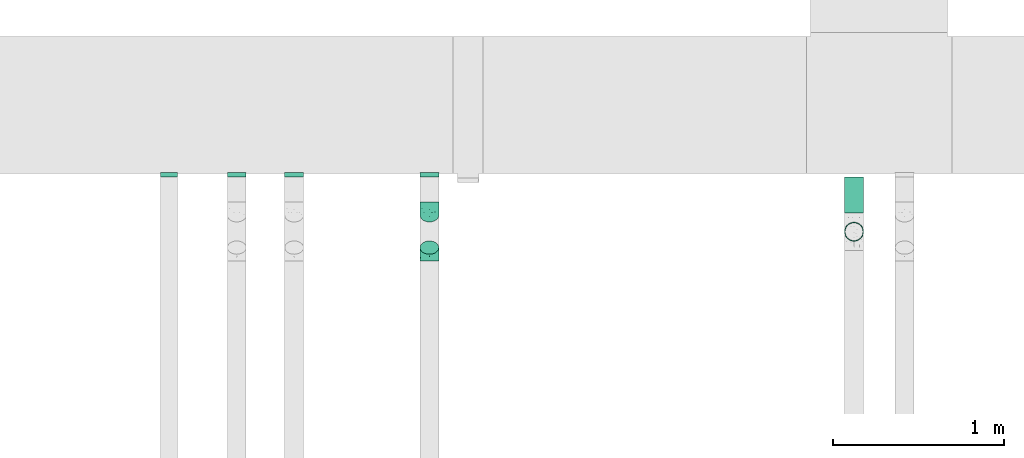
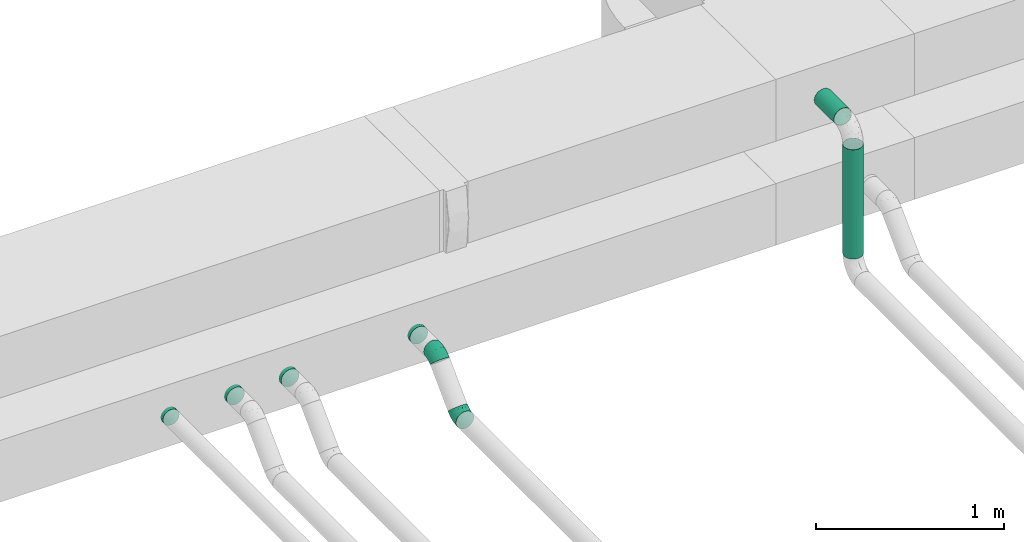
# One storey, part 45 of 91: 6 flow fittings, 2 flow segments.
"""IFC2X3 building model written with IfcOpenShell, lengths in millimetres."""

from ifc_helpers import new_model, entity, si_unit, converted_unit, derived_unit, direction, frame, origin_with_axes, origin_2d_with_axis, place, context, subcontext, project, spatial, hollow_circle, extrude, open_shell, surface_model, source, transform, mapped, material, layer, layer_set, layer_usage, type_object, element, save


model = new_model("IFC2X3")

# Units and contexts
model_context = context("Model", 3, precision=1e-05, world=origin_with_axes(), true_north=direction((0.0, 1.0)))
body_context = subcontext(model_context, "Body", "Model", "MODEL_VIEW")
ifc_project = project(units=[si_unit("AREAUNIT", "SQUARE_METRE"), si_unit("VOLUMEUNIT", "CUBIC_METRE", prefix="DECI"), si_unit("TIMEUNIT", "SECOND"), si_unit("THERMODYNAMICTEMPERATUREUNIT", "DEGREE_CELSIUS"), si_unit("PRESSUREUNIT", "PASCAL"), si_unit("MASSUNIT", "GRAM", prefix="KILO"), si_unit("LENGTHUNIT", "METRE", prefix="MILLI"), si_unit("POWERUNIT", "WATT"), si_unit("ELECTRICCURRENTUNIT", "AMPERE"), si_unit("ELECTRICVOLTAGEUNIT", "VOLT"), derived_unit("VOLUMETRICFLOWRATEUNIT", [(si_unit("VOLUMEUNIT", "CUBIC_METRE", prefix="DECI"), 1), (si_unit("TIMEUNIT", "SECOND"), -1)]), derived_unit("LINEARVELOCITYUNIT", [(si_unit("LENGTHUNIT", "METRE"), 1), (si_unit("TIMEUNIT", "SECOND"), -1)]), derived_unit("MASSDENSITYUNIT", [(si_unit("MASSUNIT", "GRAM", prefix="KILO"), 1), (si_unit("VOLUMEUNIT", "CUBIC_METRE"), -1)]), converted_unit("PLANEANGLEUNIT", "DEGREE", entity("IfcRatioMeasure", 0.01745), si_unit("PLANEANGLEUNIT", "RADIAN"), dimensions=[0, 0, 0, 0, 0, 0, 0])], contexts=[model_context])

# Site, building, storey
site_placement = place(None, origin_with_axes())
site = spatial("IfcSite", under=ifc_project, at=site_placement, CompositionType="ELEMENT")
building_placement = place(site_placement, origin_with_axes())
building = spatial("IfcBuilding", under=site, at=building_placement, Name="mc-building", CompositionType="ELEMENT")
storey_placement = place(building_placement, frame((0.0, 0.0, 8700.0), z_axis=(0.0, 0.0, 1.0), x_axis=(1.0, 0.0, 0.0)))
storey = spatial("IfcBuildingStorey", under=building, at=storey_placement, CompositionType="ELEMENT", Elevation=8700.0)

# Flow segments
ifc_material = material(Name="FZ1")
ifc_layer = layer(ifc_material, 0.0)
ifc_layer_set = layer_set([ifc_layer], Name="FZ1")
ifc_layer_usage = layer_usage(ifc_layer_set, "AXIS1", "POSITIVE", 0.0)
duct_segment_type = type_object("IfcDuctSegmentType", PredefinedType="RIGIDSEGMENT")
shared_shape_1 = source(origin_with_axes(), body_context, "Body", "SweptSolid", [
    extrude(hollow_circle(Radius=55.0, WallThickness=2.0, at=origin_2d_with_axis()), frame((0.0, 0.0, 0.0), z_axis=(1.0, 0.0, 0.0), x_axis=(0.0, 1.0, 0.0)), (0.0, 0.0, 1.0), 709.0),
])
flow_segment_1_placement = place(storey_placement, frame((22753.47863, 2612.35324, 1234.0), z_axis=(0.0, 1.0, 0.0), x_axis=(0.0, 0.0, -1.0)))
element("IfcFlowSegment", 1, at=flow_segment_1_placement, inside=storey, type_object=duct_segment_type, material=ifc_layer_usage, context=body_context, shape_type="MappedRepresentation", body=[
    mapped(shared_shape_1, transform((0.0, 0.0, 0.0), scale=1.0)),
])
shared_shape_2 = source(origin_with_axes(), body_context, "Body", "SweptSolid", [
    extrude(hollow_circle(Radius=55.0, WallThickness=2.0, at=origin_2d_with_axis()), frame((0.0, 0.0, 0.0), z_axis=(1.0, 0.0, 0.0), x_axis=(0.0, 1.0, 0.0)), (0.0, 0.0, 1.0), 208.9),
])
flow_segment_2_placement = place(storey_placement, frame((22753.47863, 2931.20513, 1344.0), z_axis=(0.0, 0.0, 1.0), x_axis=(0.0, -1.0, 0.0)))
element("IfcFlowSegment", 2, at=flow_segment_2_placement, inside=storey, type_object=duct_segment_type, material=ifc_layer_usage, context=body_context, shape_type="MappedRepresentation", body=[
    mapped(shared_shape_2, transform((0.0, 0.0, 0.0), scale=1.0)),
])

# Flow fittings
duct_fitting_type_1 = type_object("IfcDuctFittingType", Name="BU", PredefinedType="BEND")
shared_shape_3 = source(origin_with_axes(), body_context, "Body", "SurfaceModel", [
    surface_model("IfcShellBasedSurfaceModel", [(-45.56349, 0.0, -55.0), (-45.56349, -14.23505, -53.12592), (-45.56349, 14.23505, -53.12592), (-45.56349, 53.12592, 14.23505), (-45.56349, 27.5, -47.63139), (-45.56349, 38.89087, -38.89087), (-45.56349, 47.63139, -27.5), (-45.56349, -55.0, 0.0), (-45.56349, -53.12592, 14.23505), (-45.56349, -38.89087, -38.89087), (-45.56349, -27.5, -47.63139), (-45.56349, -53.12592, -14.23505), (-45.56349, -47.63139, -27.5), (-45.56349, 53.12592, -14.23505), (-45.56349, 47.63139, 27.5), (-45.56349, 38.89087, 38.89087), (-45.56349, -14.23505, 53.12592), (-45.56349, 27.5, 47.63139), (-45.56349, 14.23505, 53.12592), (-45.56349, -47.63139, 27.5), (-45.56349, -38.89087, 38.89087), (-45.56349, -27.5, 47.63139), (-45.56349, 0.0, 55.0), (-45.56349, 55.0, 0.0), (22.15256, 42.28395, -53.12592), (-6.67262, 71.10913, 0.0), (32.21826, 32.21826, -55.0), (12.77282, 51.66369, -47.63139), (-1.46223, 65.89874, -27.5), (4.71825, 59.71825, -38.89087), (59.71825, 4.71825, -38.89087), (69.78395, -5.34744, 14.23505), (51.66369, 12.77282, -47.63139), (42.28395, 22.15256, -53.12592), (65.89874, -1.46223, -27.5), (69.78395, -5.34744, -14.23505), (71.10913, -6.67262, 0.0), (-5.34744, 69.78395, -14.23505), (-5.34744, 69.78395, 14.23505), (-1.46223, 65.89874, 27.5), (4.71825, 59.71825, 38.89087), (32.21826, 32.21826, 55.0), (12.77282, 51.66369, 47.63139), (22.15256, 42.28395, 53.12592), (59.71825, 4.71825, 38.89087), (65.89874, -1.46223, 27.5), (42.28395, 22.15256, 53.12592), (51.66369, 12.77282, 47.63139), (-20.16649, 48.68621, 33.48188), (-26.97111, 35.77503, 43.63444), (-7.30443, 43.73336, 43.63444), (-17.0934, 3.74816, 55.0), (-18.00408, 15.44793, 53.78143), (-30.11707, 22.39897, 50.81337), (-7.49776, 55.63651, 33.48188), (-15.97018, 58.74288, 21.04759), (-31.18231, 52.58712, 21.04759), (-18.35174, 61.03934, 10.51509), (-28.67677, 56.60048, 10.47121), (-34.03924, 44.64267, 33.48188), (-11.52288, 27.81868, 50.81338), (1.19951, 23.16465, 53.81115), (-33.77926, 57.34403, 0.0), (5.4586, 37.12132, 50.81809), (-24.5159, 59.18663, 0.0), (-16.66281, 64.4339, 0.0), (9.43651, 14.73721, 55.0), (-6.22531, 44.36822, -43.63444), (5.4586, 37.12132, -50.81809), (-34.03924, 44.64267, -33.48188), (9.43651, 14.73721, -55.0), (-17.0934, 3.74816, -55.0), (1.19951, 23.16465, -53.81115), (-11.52288, 27.81868, -50.81338), (-30.11707, 22.39897, -50.81337), (-25.75914, 36.08917, -43.63444), (-30.24487, 52.83011, -21.04759), (-20.16649, 48.68621, -33.48188), (-7.49776, 55.63651, -33.48188), (-18.00408, 15.44793, -53.78143), (-28.68366, 56.62226, -10.35271), (-14.15883, 63.53074, -10.87592), (-15.13548, 59.23394, -21.04759), (3.19797, -7.72059, -52.16847), (3.1272, -18.04126, -47.9241), (13.63233, -32.91136, -32.06475), (45.23618, -22.99734, -20.4997), (16.67434, -40.25541, -15.9539), (-17.3935, -51.68264, -9.80849), (-2.85835, -49.37776, 0.0), (48.84421, -24.24609, -9.80849), (-16.38424, -42.76862, -30.85433), (-6.97383, -29.41689, -42.70541), (41.82739, -18.65658, -30.85433), (-15.72523, -48.24839, -20.4997), (29.28945, -13.63928, -42.80781), (26.81493, -3.56603, -49.15704), (36.93651, -32.89419, 0.0), (-15.72523, -48.24839, 20.4997), (-17.3935, -51.68264, 9.80849), (-16.38424, -42.76862, 30.85433), (16.67434, -40.25541, 15.9539), (3.19797, -7.72059, 52.16847), (10.54583, -14.96836, 47.9241), (13.63233, -32.91136, 32.06475), (45.23618, -22.99734, 20.4997), (41.82739, -18.65658, 30.85433), (-11.06635, -30.3552, 42.80781), (25.73213, -15.86964, 42.70541), (-16.43945, -21.48258, 49.15704), (48.84421, -24.24609, 9.80849)], [open_shell([[[0, 1, 2]], [[2, 3, 4]], [[5, 3, 6]], [[4, 3, 5]], [[2, 7, 8]], [[9, 7, 10]], [[1, 10, 7]], [[11, 7, 12]], [[9, 12, 7]], [[7, 2, 1]], [[13, 6, 3]], [[14, 3, 2]], [[15, 14, 2]], [[16, 17, 2]], [[2, 17, 15]], [[16, 18, 17]], [[19, 20, 2]], [[19, 2, 8]], [[20, 21, 2]], [[2, 21, 16]], [[16, 22, 18]], [[23, 13, 3]], [[24, 25, 26]], [[27, 25, 24]], [[28, 25, 29]], [[29, 25, 27]], [[30, 26, 31]], [[26, 30, 32]], [[32, 33, 26]], [[34, 31, 35]], [[31, 34, 30]], [[35, 31, 36]], [[37, 25, 28]], [[26, 38, 39]], [[26, 39, 40]], [[41, 40, 42]], [[26, 40, 41]], [[42, 43, 41]], [[26, 44, 45]], [[31, 26, 45]], [[46, 47, 26]], [[47, 44, 26]], [[46, 26, 41]], [[26, 25, 38]], [[48, 49, 50]], [[22, 51, 52]], [[17, 49, 15]], [[53, 17, 18]], [[49, 17, 53]], [[54, 50, 40]], [[48, 55, 56]], [[55, 57, 58]], [[59, 14, 15]], [[60, 53, 52]], [[50, 49, 60]], [[58, 3, 56]], [[52, 51, 61]], [[62, 23, 3]], [[63, 50, 60]], [[50, 42, 40]], [[3, 58, 62]], [[43, 61, 41]], [[62, 58, 64]], [[48, 59, 49]], [[14, 56, 3]], [[40, 39, 54]], [[57, 64, 58]], [[39, 38, 55]], [[63, 60, 61]], [[54, 55, 48]], [[65, 57, 38]], [[56, 14, 59]], [[38, 25, 65]], [[60, 52, 61]], [[49, 59, 15]], [[55, 58, 56]], [[56, 59, 48]], [[55, 54, 39]], [[50, 54, 48]], [[18, 22, 52]], [[49, 53, 60]], [[18, 52, 53]], [[61, 51, 66]], [[41, 61, 66]], [[63, 61, 43]], [[43, 42, 63]], [[50, 63, 42]], [[38, 57, 55]], [[64, 57, 65]], [[67, 27, 68]], [[69, 5, 6]], [[70, 71, 72]], [[73, 74, 75]], [[76, 77, 69]], [[29, 78, 28]], [[2, 79, 0]], [[13, 23, 62]], [[2, 74, 79]], [[5, 75, 4]], [[77, 78, 67]], [[13, 62, 80]], [[64, 80, 62]], [[81, 80, 64]], [[67, 73, 75]], [[82, 77, 76]], [[81, 64, 65]], [[76, 69, 6]], [[82, 76, 80]], [[24, 72, 68]], [[74, 2, 4]], [[27, 67, 29]], [[26, 70, 72]], [[69, 75, 5]], [[82, 28, 78]], [[72, 71, 79]], [[6, 13, 76]], [[77, 67, 75]], [[13, 80, 76]], [[82, 37, 28]], [[81, 25, 37]], [[82, 81, 37]], [[75, 69, 77]], [[67, 78, 29]], [[82, 78, 77]], [[75, 74, 4]], [[79, 74, 73]], [[79, 73, 72]], [[79, 71, 0]], [[68, 72, 73]], [[26, 72, 24]], [[67, 68, 73]], [[27, 24, 68]], [[80, 81, 82]], [[25, 81, 65]], [[1, 83, 84]], [[85, 86, 87]], [[0, 71, 1]], [[88, 87, 89]], [[90, 86, 35]], [[91, 92, 85]], [[11, 88, 7]], [[30, 34, 93]], [[11, 12, 94]], [[92, 91, 9]], [[85, 94, 91]], [[94, 85, 87]], [[95, 93, 85]], [[85, 92, 95]], [[83, 71, 70]], [[12, 9, 91]], [[70, 26, 33]], [[96, 84, 83]], [[1, 71, 83]], [[95, 96, 32]], [[95, 30, 93]], [[95, 32, 30]], [[97, 89, 87]], [[34, 86, 93]], [[36, 97, 90]], [[94, 88, 11]], [[34, 35, 86]], [[90, 87, 86]], [[93, 86, 85]], [[32, 96, 33]], [[84, 10, 1]], [[33, 83, 70]], [[94, 12, 91]], [[10, 92, 9]], [[87, 88, 94]], [[7, 88, 89]], [[36, 90, 35]], [[87, 90, 97]], [[84, 95, 92]], [[33, 96, 83]], [[95, 84, 96]], [[10, 84, 92]], [[8, 98, 19]], [[7, 89, 99]], [[19, 98, 100]], [[101, 98, 99]], [[46, 102, 103]], [[104, 105, 106]], [[100, 98, 104]], [[107, 104, 108]], [[16, 51, 22]], [[51, 16, 102]], [[107, 20, 100]], [[107, 109, 21]], [[21, 20, 107]], [[103, 47, 46]], [[101, 89, 97]], [[105, 110, 31]], [[44, 47, 108]], [[105, 104, 101]], [[107, 100, 104]], [[31, 110, 36]], [[109, 16, 21]], [[108, 106, 44]], [[105, 45, 106]], [[41, 66, 46]], [[102, 66, 51]], [[46, 66, 102]], [[104, 98, 101]], [[99, 98, 8]], [[106, 108, 104]], [[110, 101, 97]], [[45, 44, 106]], [[105, 31, 45]], [[20, 19, 100]], [[109, 103, 102]], [[101, 110, 105]], [[36, 110, 97]], [[7, 99, 8]], [[101, 99, 89]], [[103, 107, 108]], [[16, 109, 102]], [[107, 103, 109]], [[47, 103, 108]]])]),
])
for number, where, z_axis, x_axis, name in (
    (3, (20273.93073, 2740.49698, 668.0), (-1.0, 0.0, 0.0), (0.0, 0.707107, 0.707107), "BU"),
    (4, (20273.93073, 2487.49698, 415.0), (1.0, 0.0, 0.0), (0.0, 1.0, 0.0), "BU"),
):
    element("IfcFlowFitting", number, at=place(storey_placement, frame(where, z_axis=z_axis, x_axis=x_axis)), inside=storey, type_object=duct_fitting_type_1, Name=name, context=body_context, shape_type="MappedRepresentation", body=[
        mapped(shared_shape_3, transform((0.0, 0.0, 0.0), scale=1.0)),
    ])
duct_fitting_type_2 = type_object("IfcDuctFittingType", Name="CC", PredefinedType="CONNECTOR")
shared_shape_4 = source(origin_with_axes(), body_context, "Body", "SurfaceModel", [
    surface_model("IfcShellBasedSurfaceModel", [(-6.096, -38.89087, -38.89087), (-6.096, -55.0, 0.0), (-6.096, -27.5, -47.63139), (-6.096, 47.63139, -27.5), (-6.096, 53.12592, 14.23505), (-6.096, 53.12592, -14.23505), (-6.096, 55.0, 0.0), (-6.096, -53.12592, -14.23505), (-6.096, -47.63139, -27.5), (20.0, 38.89087, -38.89087), (20.0, 55.0, 0.0), (20.0, 27.5, -47.63139), (20.0, 53.12592, -14.23505), (20.0, 47.63139, -27.5), (20.0, -47.63139, -27.5), (20.0, -53.12592, 14.23505), (20.0, -53.12592, -14.23505), (20.0, -55.0, 0.0), (-6.096, 0.0, -55.0), (-6.096, -14.23505, -53.12592), (-6.096, 14.23505, -53.12592), (-6.096, 27.5, -47.63139), (-6.096, 38.89087, -38.89087), (-6.096, -53.12592, 14.23505), (-6.096, 47.63139, 27.5), (-6.096, 38.89087, 38.89087), (-6.096, -14.23505, 53.12592), (-6.096, 27.5, 47.63139), (-6.096, 14.23505, 53.12592), (-6.096, -47.63139, 27.5), (-6.096, -38.89087, 38.89087), (-6.096, -27.5, 47.63139), (-6.096, 0.0, 55.0), (0.0, 0.0, 55.0), (0.0, 14.23505, 53.12592), (0.0, 27.5, 47.63139), (0.0, 38.89087, 38.89087), (0.0, 47.63139, 27.5), (0.0, 53.12592, 14.23505), (0.0, 55.0, 0.0), (0.0, 53.12592, -14.23505), (0.0, 47.63139, -27.5), (0.0, 38.89087, -38.89087), (0.0, 27.5, -47.63139), (0.0, 14.23505, -53.12592), (0.0, 0.0, -55.0), (0.0, -14.23505, -53.12592), (0.0, -27.5, -47.63139), (0.0, -38.89087, -38.89087), (0.0, -47.63139, -27.5), (0.0, -53.12592, -14.23505), (0.0, -55.0, 0.0), (0.0, -53.12592, 14.23505), (0.0, -47.63139, 27.5), (0.0, -38.89087, 38.89087), (0.0, -27.5, 47.63139), (0.0, -14.23505, 53.12592), (20.0, 0.0, -55.0), (20.0, 14.23505, -53.12592), (20.0, -38.89087, -38.89087), (20.0, -27.5, -47.63139), (20.0, -14.23505, -53.12592), (20.0, 53.12592, 14.23505), (20.0, 47.63139, 27.5), (20.0, 38.89087, 38.89087), (20.0, 0.0, 55.0), (20.0, 27.5, 47.63139), (20.0, 14.23505, 53.12592), (20.0, -38.89087, 38.89087), (20.0, -47.63139, 27.5), (20.0, -14.23505, 53.12592), (20.0, -27.5, 47.63139)], [open_shell([[[0, 1, 2]], [[3, 4, 5]], [[6, 5, 4]], [[7, 1, 8]], [[9, 10, 11]], [[12, 10, 13]], [[14, 15, 16]], [[17, 16, 15]], [[18, 19, 20]], [[20, 4, 21]], [[3, 22, 4]], [[21, 4, 22]], [[20, 1, 23]], [[19, 2, 1]], [[0, 8, 1]], [[1, 20, 19]], [[20, 24, 4]], [[25, 24, 20]], [[26, 27, 20]], [[27, 25, 20]], [[26, 28, 27]], [[20, 29, 30]], [[29, 20, 23]], [[30, 31, 20]], [[20, 31, 26]], [[26, 32, 28]], [[32, 33, 34]], [[28, 34, 35]], [[32, 34, 28]], [[27, 36, 25]], [[27, 28, 35]], [[36, 27, 35]], [[24, 37, 38]], [[4, 38, 39]], [[25, 37, 24]], [[4, 24, 38]], [[6, 4, 39]], [[37, 25, 36]], [[6, 39, 40]], [[5, 40, 41]], [[6, 40, 5]], [[3, 42, 22]], [[3, 5, 41]], [[42, 3, 41]], [[21, 43, 44]], [[20, 44, 45]], [[22, 43, 21]], [[20, 21, 44]], [[18, 20, 45]], [[43, 22, 42]], [[18, 45, 46]], [[19, 46, 47]], [[18, 46, 19]], [[2, 48, 0]], [[2, 19, 47]], [[48, 2, 47]], [[8, 49, 50]], [[7, 50, 51]], [[0, 49, 8]], [[7, 8, 50]], [[1, 7, 51]], [[49, 0, 48]], [[1, 51, 52]], [[23, 52, 53]], [[1, 52, 23]], [[29, 54, 30]], [[29, 23, 53]], [[54, 29, 53]], [[31, 55, 56]], [[26, 56, 33]], [[30, 55, 31]], [[26, 31, 56]], [[32, 26, 33]], [[55, 30, 54]], [[10, 57, 58]], [[11, 10, 58]], [[10, 9, 13]], [[59, 57, 15]], [[57, 59, 60]], [[60, 61, 57]], [[59, 15, 14]], [[62, 63, 57]], [[57, 63, 64]], [[65, 64, 66]], [[65, 57, 64]], [[67, 65, 66]], [[68, 69, 57]], [[15, 57, 69]], [[70, 71, 57]], [[71, 68, 57]], [[70, 57, 65]], [[10, 62, 57]], [[33, 65, 67]], [[34, 67, 66]], [[33, 67, 34]], [[35, 64, 36]], [[35, 34, 66]], [[64, 35, 66]], [[37, 63, 62]], [[38, 62, 10]], [[36, 63, 37]], [[38, 37, 62]], [[39, 38, 10]], [[63, 36, 64]], [[39, 10, 12]], [[40, 12, 13]], [[39, 12, 40]], [[41, 9, 42]], [[41, 40, 13]], [[9, 41, 13]], [[43, 11, 58]], [[44, 58, 57]], [[42, 11, 43]], [[44, 43, 58]], [[45, 44, 57]], [[11, 42, 9]], [[45, 57, 61]], [[46, 61, 60]], [[45, 61, 46]], [[47, 59, 48]], [[47, 46, 60]], [[59, 47, 60]], [[49, 14, 16]], [[50, 16, 17]], [[48, 14, 49]], [[50, 49, 16]], [[51, 50, 17]], [[14, 48, 59]], [[51, 17, 15]], [[52, 15, 69]], [[51, 15, 52]], [[53, 68, 54]], [[53, 52, 69]], [[68, 53, 69]], [[55, 71, 70]], [[56, 70, 65]], [[54, 71, 55]], [[56, 55, 70]], [[33, 56, 65]], [[71, 54, 68]], [[65, 57, 66]], [[57, 64, 66]], [[65, 66, 67]], [[69, 15, 57]]])]),
])
for number, where, z_axis, x_axis, name in (
    (5, (19148.85991, 2951.20513, 668.0), (0.0, 0.0, -1.0), (0.0, -1.0, 0.0), "CC"),
    (6, (19483.88525, 2951.20513, 668.0), (0.0, 0.0, -1.0), (0.0, -1.0, 0.0), "CC"),
    (7, (20273.93073, 2951.20513, 668.0), (0.0, 0.0, -1.0), (0.0, -1.0, 0.0), "CC"),
):
    element("IfcFlowFitting", number, at=place(storey_placement, frame(where, z_axis=z_axis, x_axis=x_axis)), inside=storey, type_object=duct_fitting_type_2, Name=name, context=body_context, shape_type="MappedRepresentation", body=[
        mapped(shared_shape_4, transform((0.0, 0.0, 0.0), scale=1.0)),
    ])
shared_shape_5 = source(origin_with_axes(), body_context, "Body", "SurfaceModel", [
    surface_model("IfcShellBasedSurfaceModel", [(-6.096, -35.35534, -35.35534), (-6.096, -50.0, 0.0), (-6.096, -25.0, -43.30127), (-6.096, 43.30127, -25.0), (-6.096, 48.29629, 12.94095), (-6.096, 48.29629, -12.94095), (20.0, -43.30127, -25.0), (20.0, -35.35534, -35.35534), (20.0, -48.29629, 12.94095), (20.0, 35.35534, -35.35534), (20.0, 50.0, 0.0), (20.0, 25.0, -43.30127), (20.0, -48.29629, -12.94095), (20.0, -50.0, 0.0), (-6.096, 0.0, -50.0), (-6.096, -12.94095, -48.29629), (-6.096, 12.94095, -48.29629), (-6.096, 25.0, -43.30127), (-6.096, 35.35534, -35.35534), (-6.096, -48.29629, 12.94095), (-6.096, -48.29629, -12.94095), (-6.096, -43.30127, -25.0), (-6.096, 43.30127, 25.0), (-6.096, 35.35534, 35.35534), (-6.096, 25.0, 43.30127), (-6.096, -12.94095, 48.29629), (-6.096, 12.94095, 48.29629), (-6.096, -43.30127, 25.0), (-6.096, -35.35534, 35.35534), (-6.096, -25.0, 43.30127), (-6.096, 0.0, 50.0), (-6.096, 50.0, 0.0), (0.0, 0.0, 50.0), (0.0, 12.94095, 48.29629), (0.0, 25.0, 43.30127), (0.0, 35.35534, 35.35534), (0.0, 43.30127, 25.0), (0.0, 48.29629, 12.94095), (0.0, 50.0, 0.0), (0.0, 48.29629, -12.94095), (0.0, 43.30127, -25.0), (0.0, 35.35534, -35.35534), (0.0, 25.0, -43.30127), (0.0, 12.94095, -48.29629), (0.0, 0.0, -50.0), (0.0, -12.94095, -48.29629), (0.0, -25.0, -43.30127), (0.0, -35.35534, -35.35534), (0.0, -43.30127, -25.0), (0.0, -48.29629, -12.94095), (0.0, -50.0, 0.0), (0.0, -48.29629, 12.94095), (0.0, -43.30127, 25.0), (0.0, -35.35534, 35.35534), (0.0, -25.0, 43.30127), (0.0, -12.94095, 48.29629), (20.0, 12.94095, -48.29629), (20.0, 0.0, -50.0), (20.0, 43.30127, -25.0), (20.0, -25.0, -43.30127), (20.0, -12.94095, -48.29629), (20.0, 48.29629, -12.94095), (20.0, 48.29629, 12.94095), (20.0, 43.30127, 25.0), (20.0, 35.35534, 35.35534), (20.0, 25.0, 43.30127), (20.0, 0.0, 50.0), (20.0, 12.94095, 48.29629), (20.0, -43.30127, 25.0), (20.0, -35.35534, 35.35534), (20.0, -25.0, 43.30127), (20.0, -12.94095, 48.29629)], [open_shell([[[0, 1, 2]], [[3, 4, 5]], [[6, 7, 8]], [[9, 10, 11]], [[6, 8, 12]], [[13, 12, 8]], [[14, 15, 16]], [[16, 4, 17]], [[3, 18, 4]], [[17, 4, 18]], [[16, 1, 19]], [[15, 2, 1]], [[20, 1, 21]], [[0, 21, 1]], [[1, 16, 15]], [[22, 4, 16]], [[23, 22, 16]], [[24, 16, 25]], [[24, 23, 16]], [[24, 25, 26]], [[19, 27, 16]], [[16, 27, 28]], [[16, 28, 29]], [[25, 16, 29]], [[25, 30, 26]], [[31, 5, 4]], [[30, 32, 33]], [[26, 33, 34]], [[30, 33, 26]], [[24, 35, 23]], [[24, 26, 34]], [[35, 24, 34]], [[22, 36, 37]], [[4, 37, 38]], [[23, 36, 22]], [[4, 22, 37]], [[31, 4, 38]], [[36, 23, 35]], [[31, 38, 39]], [[5, 39, 40]], [[31, 39, 5]], [[3, 41, 18]], [[3, 5, 40]], [[41, 3, 40]], [[17, 42, 43]], [[16, 43, 44]], [[18, 42, 17]], [[16, 17, 43]], [[14, 16, 44]], [[42, 18, 41]], [[14, 44, 45]], [[15, 45, 46]], [[14, 45, 15]], [[2, 47, 0]], [[2, 15, 46]], [[47, 2, 46]], [[21, 48, 49]], [[20, 49, 50]], [[0, 48, 21]], [[20, 21, 49]], [[1, 20, 50]], [[48, 0, 47]], [[1, 50, 51]], [[19, 51, 52]], [[1, 51, 19]], [[27, 53, 28]], [[27, 19, 52]], [[53, 27, 52]], [[29, 54, 55]], [[25, 55, 32]], [[28, 54, 29]], [[25, 29, 55]], [[30, 25, 32]], [[54, 28, 53]], [[56, 10, 57]], [[11, 10, 56]], [[10, 9, 58]], [[7, 57, 8]], [[57, 7, 59]], [[59, 60, 57]], [[8, 6, 7]], [[12, 8, 13]], [[58, 61, 10]], [[57, 62, 63]], [[57, 63, 64]], [[65, 66, 64]], [[66, 57, 64]], [[67, 66, 65]], [[57, 68, 8]], [[69, 68, 57]], [[70, 69, 57]], [[71, 70, 57]], [[71, 57, 66]], [[57, 10, 62]], [[32, 66, 67]], [[33, 67, 65]], [[32, 67, 33]], [[34, 64, 35]], [[34, 33, 65]], [[64, 34, 65]], [[36, 63, 62]], [[37, 62, 10]], [[35, 63, 36]], [[37, 36, 62]], [[38, 37, 10]], [[63, 35, 64]], [[38, 10, 61]], [[39, 61, 58]], [[38, 61, 39]], [[40, 9, 41]], [[40, 39, 58]], [[9, 40, 58]], [[42, 11, 56]], [[43, 56, 57]], [[41, 11, 42]], [[43, 42, 56]], [[44, 43, 57]], [[11, 41, 9]], [[44, 57, 60]], [[45, 60, 59]], [[44, 60, 45]], [[46, 7, 47]], [[46, 45, 59]], [[7, 46, 59]], [[48, 6, 12]], [[49, 12, 13]], [[47, 6, 48]], [[49, 48, 12]], [[50, 49, 13]], [[6, 47, 7]], [[50, 13, 8]], [[51, 8, 68]], [[50, 8, 51]], [[52, 69, 53]], [[52, 51, 68]], [[69, 52, 68]], [[54, 70, 71]], [[55, 71, 66]], [[53, 70, 54]], [[55, 54, 71]], [[32, 55, 66]], [[70, 53, 69]], [[68, 8, 57]], [[70, 57, 71]], [[66, 71, 57]], [[10, 62, 57]], [[25, 24, 16]], [[25, 26, 24]]])]),
])
flow_fitting_placement = place(storey_placement, frame((18753.74821, 2951.20513, 668.0), z_axis=(0.0, 0.0, -1.0), x_axis=(0.0, -1.0, 0.0)))
element("IfcFlowFitting", 8, at=flow_fitting_placement, inside=storey, type_object=duct_fitting_type_2, Name="CC", context=body_context, shape_type="MappedRepresentation", body=[
    mapped(shared_shape_5, transform((0.0, 0.0, 0.0), scale=1.0)),
])

save(model, "model.ifc")
